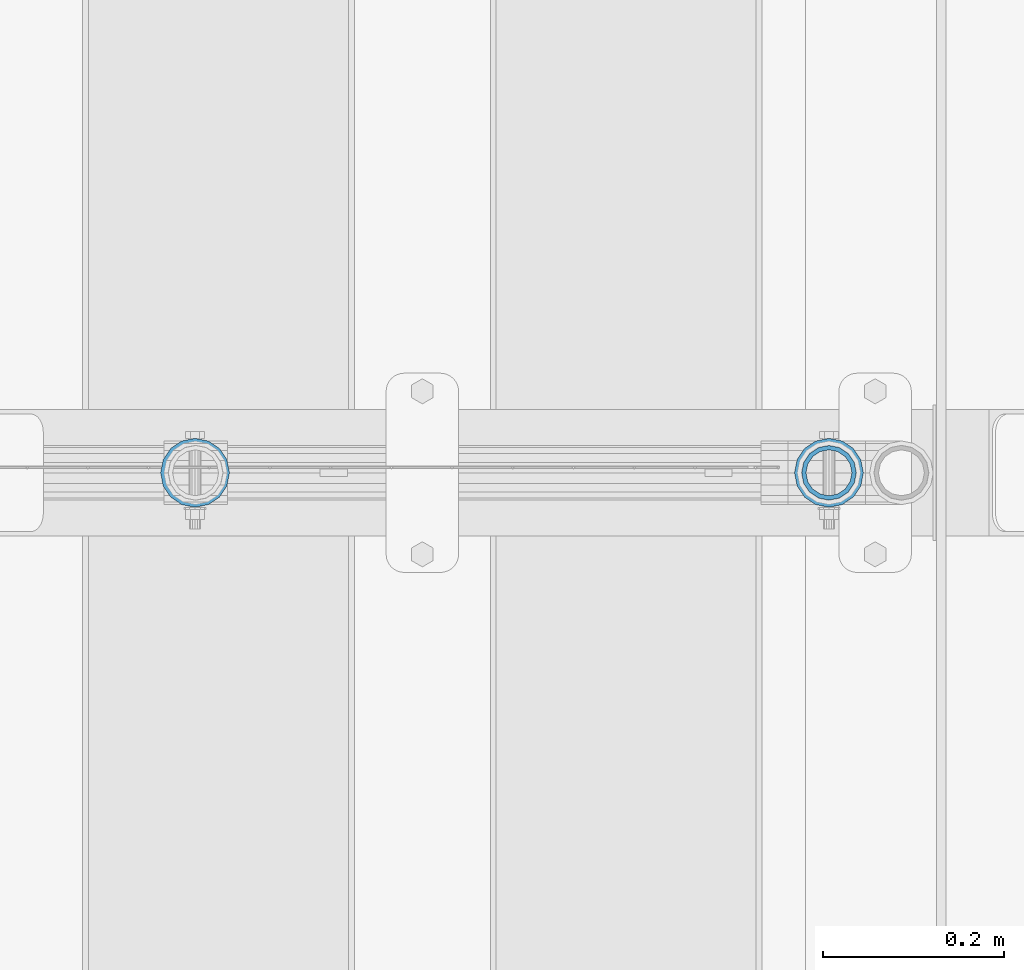
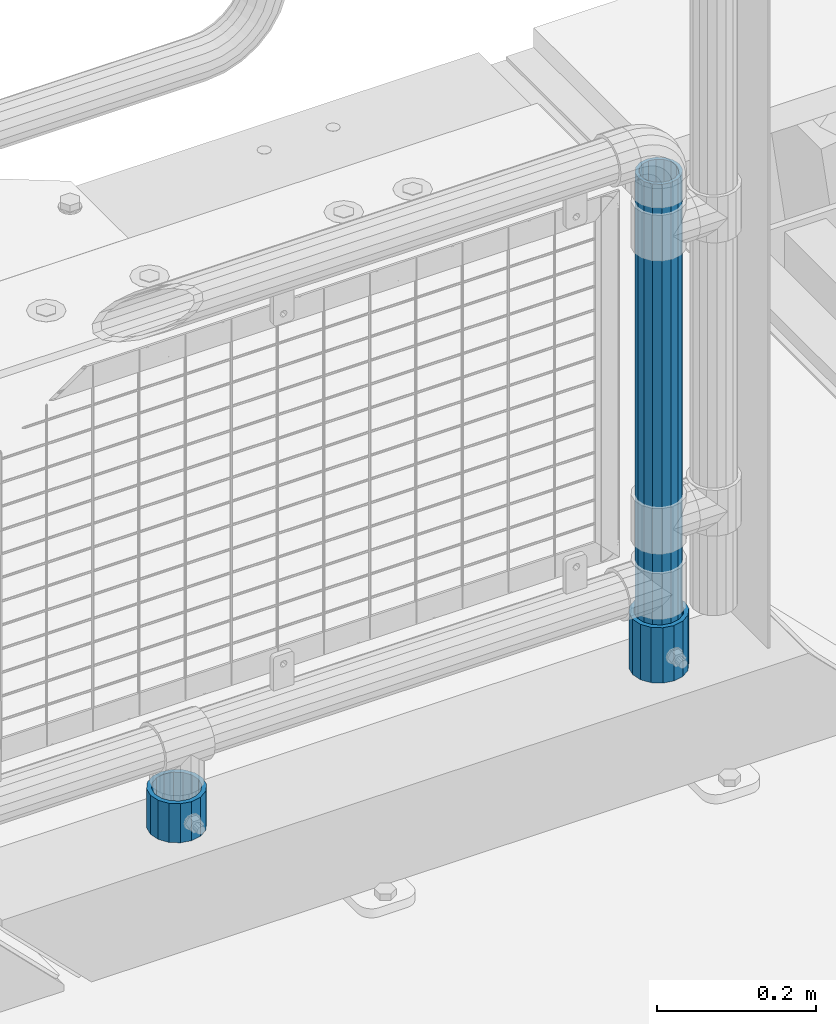
# One storey, part 108 of 242: 3 columns.
"""IFC2X3 building model written with IfcOpenShell, lengths in millimetres."""

import ifcopenshell
import ifcopenshell.guid

model = None  # the IFC model being written
_history = None  # IfcOwnerHistory: only IFC2X3 demands one
_inside = {}  # id of a spatial element -> (the spatial element, [elements in it])
_under = {}  # id of a project, library or spatial element -> (it, [spatial elements below it])
_declared = {}  # id of a project -> (the project, [libraries it declares])
_typed = {}  # id of a type object -> (the type object, [elements of that type])
_made_of = {}  # id of a material, layer set ... -> (it, [elements and type objects made of it])


def new_model(schema):
    """Start an empty IFC model of exactly this schema.

    Asked for "IFC4X3", IfcOpenShell would pick the latest addendum, in which some entities
    have other attributes; the version numbers below select the first issue.
    IFC2X3 requires an IfcOwnerHistory on every rooted entity: one is made here for all.
    """
    global model, _history
    if schema == "IFC4X3":
        model = ifcopenshell.file(schema_version=(4, 3, 0, 0))
    else:
        model = ifcopenshell.file(schema=schema)
    _inside.clear()
    _under.clear()
    _declared.clear()
    _typed.clear()
    _made_of.clear()
    _history = None
    if model.schema == "IFC2X3":
        org = make("IfcOrganization", Name="unknown")
        user = make(
            "IfcPersonAndOrganization",
            ThePerson=make("IfcPerson", FamilyName="unknown"),
            TheOrganization=org,
        )
        app = make(
            "IfcApplication",
            ApplicationDeveloper=org,
            Version="unknown",
            ApplicationFullName="unknown",
            ApplicationIdentifier="unknown",
        )
        _history = make(
            "IfcOwnerHistory",
            OwningUser=user,
            OwningApplication=app,
            ChangeAction="ADDED",
            CreationDate=0,
        )
    return model


def make(cls, **values):
    """One entity of the class cls with the attributes given. An attribute that is None is left unset."""
    return model.create_entity(
        cls, **{name: value for name, value in values.items() if value is not None}
    )


def rooted(cls, **values):
    """An entity with a GlobalId (a new one), such as an element, a storey or a relation."""
    return make(cls, GlobalId=ifcopenshell.guid.new(), OwnerHistory=_history, **values)


def si_unit(unit_type, name, prefix=None):
    """IfcSIUnit, for example si_unit("LENGTHUNIT", "METRE", prefix="MILLI")."""
    return make("IfcSIUnit", UnitType=unit_type, Prefix=prefix, Name=name)


def assignment(units):
    """IfcUnitAssignment: the units of a project."""
    return None if units is None else make("IfcUnitAssignment", Units=units)


def point(xyz):
    """IfcCartesianPoint."""
    return None if xyz is None else make("IfcCartesianPoint", Coordinates=xyz)


def direction(xyz):
    """IfcDirection."""
    return None if xyz is None else make("IfcDirection", DirectionRatios=xyz)


def frame(location, z_axis=None, x_axis=None):
    """IfcAxis2Placement3D, a coordinate frame: its origin and axes. An axis left out is left unset."""
    return make(
        "IfcAxis2Placement3D",
        Location=point(location),
        Axis=direction(z_axis),
        RefDirection=direction(x_axis),
    )


def origin_with_axes():
    """The frame at (0, 0, 0) with the z axis (0, 0, 1) and the x axis (1, 0, 0) written out."""
    return frame((0.0, 0.0, 0.0), z_axis=(0.0, 0.0, 1.0), x_axis=(1.0, 0.0, 0.0))


def place(relative_to, where):
    """IfcLocalPlacement: puts the frame where relative to a parent placement (None: the world)."""
    return make(
        "IfcLocalPlacement", PlacementRelTo=relative_to, RelativePlacement=where
    )


def context(
    kind, dimensions, precision=None, world=None, true_north=None, identifier=None
):
    """IfcGeometricRepresentationContext, for example the 3D "Model" context."""
    return make(
        "IfcGeometricRepresentationContext",
        ContextIdentifier=identifier,
        ContextType=kind,
        CoordinateSpaceDimension=dimensions,
        Precision=precision,
        WorldCoordinateSystem=world,
        TrueNorth=true_north,
    )


def subcontext(parent, identifier, kind, view, scale=None):
    """IfcGeometricRepresentationSubContext, for example "Body" below "Model"."""
    return make(
        "IfcGeometricRepresentationSubContext",
        ContextIdentifier=identifier,
        ContextType=kind,
        ParentContext=parent,
        TargetScale=scale,
        TargetView=view,
    )


def project(units=None, contexts=None):
    """IfcProject with its units and contexts."""
    return rooted(
        "IfcProject",
        Name="project",
        RepresentationContexts=contexts,
        UnitsInContext=assignment(units),
    )


def spatial(cls, under=None, at=None, **own):
    """A site, building, storey or space (cls), placed at a placement, below another one or the project."""
    s = rooted(cls, ObjectPlacement=at, **own)
    if under is not None:
        _under.setdefault(under.id(), (under, []))[1].append(s)
    return s


def faces_of(points, faces, orient=None, outer=None):
    """IfcFace entities. A face is a list of loops; a loop is a list of indices into points, from 0.

    orient and outer hold one flag for each loop. By default every Orientation is true, the
    first loop of a face is its IfcFaceOuterBound and the others are IfcFaceBound.
    """
    made = []
    for i, loops in enumerate(faces):
        bounds = []
        for j, loop in enumerate(loops):
            is_outer = j == 0 if outer is None else outer[i][j]
            bounds.append(
                make(
                    "IfcFaceOuterBound" if is_outer else "IfcFaceBound",
                    Bound=make("IfcPolyLoop", Polygon=[points[k] for k in loop]),
                    Orientation=True if orient is None else orient[i][j],
                )
            )
        made.append(make("IfcFace", Bounds=bounds))
    return made


def faceted_brep(points, faces, orient=None, outer=None, voids=None):
    """IfcFacetedBrep: a solid bounded by flat faces; with voids (closed shells), ...WithVoids."""
    shared = [point(p) for p in points]
    hull = make("IfcClosedShell", CfsFaces=faces_of(shared, faces, orient, outer))
    if voids is None:
        return make("IfcFacetedBrep", Outer=hull)
    return make(
        "IfcFacetedBrepWithVoids",
        Outer=hull,
        Voids=[
            make(cls, CfsFaces=faces_of(shared, fs, o, b)) for cls, fs, o, b in voids
        ],
    )


def shape(context_of_items, identifier, shape_type, items):
    """IfcShapeRepresentation: the items that make up one representation, for example the "Body"."""
    return make(
        "IfcShapeRepresentation",
        ContextOfItems=context_of_items,
        RepresentationIdentifier=identifier,
        RepresentationType=shape_type,
        Items=items,
    )


def material(Name=None, Category=None):
    """IfcMaterial."""
    return make("IfcMaterial", Name=Name, Category=Category)


def made_of(thing, what):
    """Note that an element or type object is made of a material, layer set ...; save() writes the relation."""
    if what is not None:
        _made_of.setdefault(what.id(), (what, []))[1].append(thing)
    return thing


def type_object(cls, material=None, **own):
    """A type object (cls), such as IfcWallType, which elements share."""
    return made_of(rooted(cls, **own), material)


def element(
    cls,
    number,
    at=None,
    inside=None,
    cuts=None,
    type_object=None,
    material=None,
    context=None,
    identifier="Body",
    shape_type=None,
    held_by="IfcProductDefinitionShape",
    body=None,
    shapes=None,
    **own,
):
    """One element of the class cls, such as IfcWall. Its Tag is "e" and its number.

    at: its placement. inside: the storey or other place that contains it. cuts: it is an
    opening in that element (IfcRelVoidsElement). A single representation is given by context,
    identifier, shape_type and body (its items); several are given by shapes. held_by: the class
    of the entity that holds the representations. save() writes the other relations.
    """
    e = rooted(cls, Tag="e%d" % number, ObjectPlacement=at, **own)
    if body is not None:
        shapes = [shape(context, identifier, shape_type, body)]
    if shapes is not None:
        e.Representation = make(held_by, Representations=shapes)
    if inside is not None:
        _inside.setdefault(inside.id(), (inside, []))[1].append(e)
    if cuts is not None:
        rooted(
            "IfcRelVoidsElement", RelatingBuildingElement=cuts, RelatedOpeningElement=e
        )
    if type_object is not None:
        _typed.setdefault(type_object.id(), (type_object, []))[1].append(e)
    return made_of(e, material)


def aggregate(whole, parts):
    """IfcRelAggregates: a whole, such as a stair, and the parts it consists of."""
    return rooted("IfcRelAggregates", RelatingObject=whole, RelatedObjects=parts)


def save(model, path):
    """Write the relations noted so far, then the file.

    IfcRelAggregates (storeys below a building ...), IfcRelContainedInSpatialStructure (elements
    in a storey), IfcRelDefinesByType, IfcRelAssociatesMaterial and IfcRelDeclares: one each for
    every whole, place, type object, material and project.
    """
    for whole, parts in _under.values():
        aggregate(whole, parts)
    for where, things in _inside.values():
        rooted(
            "IfcRelContainedInSpatialStructure",
            RelatedElements=things,
            RelatingStructure=where,
        )
    for kind, things in _typed.values():
        rooted("IfcRelDefinesByType", RelatedObjects=things, RelatingType=kind)
    for what, things in _made_of.values():
        rooted("IfcRelAssociatesMaterial", RelatedObjects=things, RelatingMaterial=what)
    for by, libraries in _declared.values():
        rooted("IfcRelDeclares", RelatingContext=by, RelatedDefinitions=libraries)
    model.write(path)


model = new_model("IFC2X3")

# Units and contexts
model_context = context("Model", 3, precision=1e-05, world=origin_with_axes())
body_context = subcontext(model_context, "Body", "Model", "MODEL_VIEW")
ifc_project = project(units=[si_unit("LENGTHUNIT", "METRE", prefix="MILLI"), si_unit("AREAUNIT", "SQUARE_METRE"), si_unit("VOLUMEUNIT", "CUBIC_METRE"), si_unit("MASSUNIT", "GRAM", prefix="KILO"), si_unit("TIMEUNIT", "SECOND"), si_unit("PLANEANGLEUNIT", "RADIAN"), si_unit("SOLIDANGLEUNIT", "STERADIAN"), si_unit("THERMODYNAMICTEMPERATUREUNIT", "DEGREE_CELSIUS"), si_unit("LUMINOUSINTENSITYUNIT", "LUMEN")], contexts=[model_context])

# Site, building, storey
site_placement = place(None, origin_with_axes())
site = spatial("IfcSite", under=ifc_project, at=site_placement, CompositionType="ELEMENT")
building_placement = place(site_placement, origin_with_axes())
building = spatial("IfcBuilding", under=site, at=building_placement, Name="Standard", CompositionType="ELEMENT")
storey_placement = place(building_placement, origin_with_axes())
storey = spatial("IfcBuildingStorey", under=building, at=storey_placement, Name="Undefined", CompositionType="ELEMENT", Elevation=0.0)

# Columns
ifc_material = material()
column_type_1 = type_object("IfcColumnType", PredefinedType="NOTDEFINED")
column_1_placement = place(storey_placement, frame((-22656.0, -19335.5, 168.02), z_axis=(-1.0, 0.0, 0.0), x_axis=(0.0, 0.0, 1.0)))
element("IfcColumn", 1, at=column_1_placement, inside=storey, type_object=column_type_1, material=ifc_material, context=body_context, shape_type="Brep", body=[
    faceted_brep([(0.0, -25.3499999999985, 0.0), (0.0, -23.4203461491597, 9.70102501045403), (760.0, -23.4203461491597, 9.70102501045403), (760.0, -25.3499999999985, 0.0), (0.0, -17.9251569030785, 17.9251569030785), (760.0, -17.9251569030785, 17.9251569030785), (0.0, -9.70102501045403, 23.4203461491597), (760.0, -9.70102501045403, 23.4203461491597), (0.0, 0.0, 25.3499999999985), (760.0, 0.0, 25.3499999999985), (0.0, 9.70102501045403, 23.4203461491597), (760.0, 9.70102501045403, 23.4203461491597), (0.0, 17.9251569030785, 17.9251569030785), (760.0, 17.9251569030785, 17.9251569030785), (0.0, 23.4203461491597, 9.70102501045403), (760.0, 23.4203461491597, 9.70102501045403), (0.0, 25.3499999999985, 0.0), (760.0, 25.3499999999985, 0.0), (0.0, 23.4203461491597, -9.70102501045403), (760.0, 23.4203461491597, -9.70102501045403), (0.0, 17.9251569030785, -17.9251569030785), (760.0, 17.9251569030785, -17.9251569030785), (0.0, 9.70102501045403, -23.4203461491597), (760.0, 9.70102501045403, -23.4203461491597), (0.0, 0.0, -25.3499999999985), (760.0, 0.0, -25.3499999999985), (0.0, -9.70102501045403, -23.4203461491597), (760.0, -9.70102501045403, -23.4203461491597), (0.0, -17.9251569030785, -17.9251569030785), (760.0, -17.9251569030785, -17.9251569030785), (0.0, -23.4203461491597, -9.70102501045403), (760.0, -23.4203461491597, -9.70102501045403), (0.0, -30.1500000000015, 0.0), (0.0, -27.8549679052157, -11.5379054858058), (760.0, -27.8549679052157, -11.5379054858058), (760.0, -30.1500000000015, 0.0), (0.0, -21.3192694527752, -21.3192694527752), (760.0, -21.3192694527752, -21.3192694527752), (0.0, -11.5379054858058, -27.8549679052157), (760.0, -11.5379054858058, -27.8549679052157), (0.0, 0.0, -30.1500000000015), (760.0, 0.0, -30.1500000000015), (0.0, 11.5379054858058, -27.8549679052157), (760.0, 11.5379054858058, -27.8549679052157), (0.0, 21.3192694527752, -21.3192694527752), (760.0, 21.3192694527752, -21.3192694527752), (0.0, 27.8549679052157, -11.5379054858058), (760.0, 27.8549679052157, -11.5379054858058), (0.0, 30.1500000000015, 0.0), (760.0, 30.1500000000015, 0.0), (0.0, 27.8549679052157, 11.5379054858058), (760.0, 27.8549679052157, 11.5379054858058), (0.0, 21.3192694527752, 21.3192694527752), (760.0, 21.3192694527752, 21.3192694527752), (0.0, 11.5379054858058, 27.8549679052157), (760.0, 11.5379054858058, 27.8549679052157), (0.0, 0.0, 30.1500000000015), (760.0, 0.0, 30.1500000000015), (0.0, -11.5379054858058, 27.8549679052157), (760.0, -11.5379054858058, 27.8549679052157), (0.0, -21.3192694527752, 21.3192694527752), (760.0, -21.3192694527752, 21.3192694527752), (0.0, -27.8549679052157, 11.5379054858058), (760.0, -27.8549679052157, 11.5379054858058)], [[[0, 1, 2, 3]], [[1, 4, 5, 2]], [[4, 6, 7, 5]], [[6, 8, 9, 7]], [[8, 10, 11, 9]], [[10, 12, 13, 11]], [[12, 14, 15, 13]], [[14, 16, 17, 15]], [[16, 18, 19, 17]], [[18, 20, 21, 19]], [[20, 22, 23, 21]], [[22, 24, 25, 23]], [[24, 26, 27, 25]], [[26, 28, 29, 27]], [[28, 30, 31, 29]], [[30, 0, 3, 31]], [[32, 33, 34, 35]], [[33, 36, 37, 34]], [[36, 38, 39, 37]], [[38, 40, 41, 39]], [[40, 42, 43, 41]], [[42, 44, 45, 43]], [[44, 46, 47, 45]], [[46, 48, 49, 47]], [[48, 50, 51, 49]], [[50, 52, 53, 51]], [[52, 54, 55, 53]], [[54, 56, 57, 55]], [[56, 58, 59, 57]], [[58, 60, 61, 59]], [[60, 62, 63, 61]], [[62, 32, 35, 63]], [[37, 39, 41, 43, 45, 47, 49, 51, 53, 55, 57, 59, 61, 63, 35, 34], [5, 7, 9, 11, 13, 15, 17, 19, 21, 23, 25, 27, 29, 31, 3, 2]], [[62, 60, 58, 56, 54, 52, 50, 48, 46, 44, 42, 40, 38, 36, 33, 32], [30, 28, 26, 24, 22, 20, 18, 16, 14, 12, 10, 8, 6, 4, 1, 0]]]),
])
column_type_2 = type_object("IfcColumnType", PredefinedType="NOTDEFINED")
column_2_placement = place(storey_placement, frame((-23356.0, -19335.5, 168.019999999998), z_axis=(0.0, 1.0, 0.0), x_axis=(0.0, 0.0, 1.0)))
element("IfcColumn", 2, at=column_2_placement, inside=storey, type_object=column_type_2, material=ifc_material, context=body_context, shape_type="Brep", body=[
    faceted_brep([(0.0, -31.75, 0.0), (0.0, -29.3331751572332, 12.1501989775934), (60.0, -29.3331751572332, 12.1501989775934), (60.0, -31.75, 0.0), (0.0, -22.4506403026717, 22.4506403026717), (60.0, -22.4506403026717, 22.4506403026717), (0.0, -12.1501989775934, 29.3331751572332), (60.0, -12.1501989775934, 29.3331751572332), (0.0, 0.0, 31.75), (60.0, 0.0, 31.75), (0.0, 12.1501989775934, 29.3331751572332), (60.0, 12.1501989775934, 29.3331751572332), (0.0, 22.4506403026717, 22.4506403026717), (60.0, 22.4506403026717, 22.4506403026717), (0.0, 29.3331751572332, 12.1501989775934), (60.0, 29.3331751572332, 12.1501989775934), (0.0, 31.75, 0.0), (60.0, 31.75, 0.0), (0.0, 29.3331751572332, -12.1501989775934), (60.0, 29.3331751572332, -12.1501989775934), (0.0, 22.4506403026717, -22.4506403026717), (60.0, 22.4506403026717, -22.4506403026717), (0.0, 12.1501989775934, -29.3331751572332), (60.0, 12.1501989775934, -29.3331751572332), (0.0, 0.0, -31.75), (60.0, 0.0, -31.75), (0.0, -12.1501989775934, -29.3331751572332), (60.0, -12.1501989775934, -29.3331751572332), (0.0, -22.4506403026717, -22.4506403026717), (60.0, -22.4506403026717, -22.4506403026717), (0.0, -29.3331751572332, -12.1501989775934), (60.0, -29.3331751572332, -12.1501989775934), (0.0, -38.0499999999993, 0.0), (0.0, -35.1536162120537, -14.5611046014928), (60.0, -35.1536162120537, -14.5611046014928), (60.0, -38.0499999999993, 0.0), (0.0, -26.9054130241493, -26.9054130241493), (60.0, -26.9054130241493, -26.9054130241493), (0.0, -14.5611046014928, -35.1536162120537), (60.0, -14.5611046014928, -35.1536162120537), (0.0, 0.0, -38.0499999999993), (60.0, 0.0, -38.0499999999993), (0.0, 14.5611046014928, -35.1536162120537), (60.0, 14.5611046014928, -35.1536162120537), (0.0, 26.9054130241493, -26.9054130241493), (60.0, 26.9054130241493, -26.9054130241493), (0.0, 35.1536162120537, -14.5611046014928), (60.0, 35.1536162120537, -14.5611046014928), (0.0, 38.0499999999993, 0.0), (60.0, 38.0499999999993, 0.0), (0.0, 35.1536162120537, 14.5611046014928), (60.0, 35.1536162120537, 14.5611046014928), (0.0, 26.9054130241493, 26.9054130241493), (60.0, 26.9054130241493, 26.9054130241493), (0.0, 14.5611046014928, 35.1536162120537), (60.0, 14.5611046014928, 35.1536162120537), (0.0, 0.0, 38.0499999999993), (60.0, 0.0, 38.0499999999993), (0.0, -14.5611046014928, 35.1536162120537), (60.0, -14.5611046014928, 35.1536162120537), (0.0, -26.9054130241493, 26.9054130241493), (60.0, -26.9054130241493, 26.9054130241493), (0.0, -35.1536162120537, 14.5611046014928), (60.0, -35.1536162120537, 14.5611046014928)], [[[0, 1, 2, 3]], [[1, 4, 5, 2]], [[4, 6, 7, 5]], [[6, 8, 9, 7]], [[8, 10, 11, 9]], [[10, 12, 13, 11]], [[12, 14, 15, 13]], [[14, 16, 17, 15]], [[16, 18, 19, 17]], [[18, 20, 21, 19]], [[20, 22, 23, 21]], [[22, 24, 25, 23]], [[24, 26, 27, 25]], [[26, 28, 29, 27]], [[28, 30, 31, 29]], [[30, 0, 3, 31]], [[32, 33, 34, 35]], [[33, 36, 37, 34]], [[36, 38, 39, 37]], [[38, 40, 41, 39]], [[40, 42, 43, 41]], [[42, 44, 45, 43]], [[44, 46, 47, 45]], [[46, 48, 49, 47]], [[48, 50, 51, 49]], [[50, 52, 53, 51]], [[52, 54, 55, 53]], [[54, 56, 57, 55]], [[56, 58, 59, 57]], [[58, 60, 61, 59]], [[60, 62, 63, 61]], [[62, 32, 35, 63]], [[37, 39, 41, 43, 45, 47, 49, 51, 53, 55, 57, 59, 61, 63, 35, 34], [5, 7, 9, 11, 13, 15, 17, 19, 21, 23, 25, 27, 29, 31, 3, 2]], [[62, 60, 58, 56, 54, 52, 50, 48, 46, 44, 42, 40, 38, 36, 33, 32], [30, 28, 26, 24, 22, 20, 18, 16, 14, 12, 10, 8, 6, 4, 1, 0]]]),
])
column_3_placement = place(storey_placement, frame((-22656.0, -19335.5, 168.02), z_axis=(0.0, 1.0, 0.0), x_axis=(0.0, 0.0, 1.0)))
element("IfcColumn", 3, at=column_3_placement, inside=storey, type_object=column_type_2, material=ifc_material, context=body_context, shape_type="Brep", body=[
    faceted_brep([(0.0, -31.75, 0.0), (0.0, -29.3331751572332, 12.1501989775934), (85.0, -29.3331751572332, 12.1501989775934), (85.0, -31.75, 0.0), (0.0, -22.4506403026717, 22.4506403026717), (85.0, -22.4506403026717, 22.4506403026717), (0.0, -12.1501989775934, 29.3331751572332), (85.0, -12.1501989775934, 29.3331751572332), (0.0, 0.0, 31.75), (85.0, 0.0, 31.75), (0.0, 12.1501989775934, 29.3331751572332), (85.0, 12.1501989775934, 29.3331751572332), (0.0, 22.4506403026717, 22.4506403026717), (85.0, 22.4506403026717, 22.4506403026717), (0.0, 29.3331751572332, 12.1501989775934), (85.0, 29.3331751572332, 12.1501989775934), (0.0, 31.75, 0.0), (85.0, 31.75, 0.0), (0.0, 29.3331751572332, -12.1501989775934), (85.0, 29.3331751572332, -12.1501989775934), (0.0, 22.4506403026717, -22.4506403026717), (85.0, 22.4506403026717, -22.4506403026717), (0.0, 12.1501989775934, -29.3331751572332), (85.0, 12.1501989775934, -29.3331751572332), (0.0, 0.0, -31.75), (85.0, 0.0, -31.75), (0.0, -12.1501989775934, -29.3331751572332), (85.0, -12.1501989775934, -29.3331751572332), (0.0, -22.4506403026717, -22.4506403026717), (85.0, -22.4506403026717, -22.4506403026717), (0.0, -29.3331751572332, -12.1501989775934), (85.0, -29.3331751572332, -12.1501989775934), (0.0, -38.0499999999993, 0.0), (0.0, -35.1536162120537, -14.5611046014928), (85.0, -35.1536162120537, -14.5611046014928), (85.0, -38.0499999999993, 0.0), (0.0, -26.9054130241493, -26.9054130241493), (85.0, -26.9054130241493, -26.9054130241493), (0.0, -14.5611046014928, -35.1536162120537), (85.0, -14.5611046014928, -35.1536162120537), (0.0, 0.0, -38.0499999999993), (85.0, 0.0, -38.0499999999993), (0.0, 14.5611046014928, -35.1536162120537), (85.0, 14.5611046014928, -35.1536162120537), (0.0, 26.9054130241493, -26.9054130241493), (85.0, 26.9054130241493, -26.9054130241493), (0.0, 35.1536162120537, -14.5611046014928), (85.0, 35.1536162120537, -14.5611046014928), (0.0, 38.0499999999993, 0.0), (85.0, 38.0499999999993, 0.0), (0.0, 35.1536162120537, 14.5611046014928), (85.0, 35.1536162120537, 14.5611046014928), (0.0, 26.9054130241493, 26.9054130241493), (85.0, 26.9054130241493, 26.9054130241493), (0.0, 14.5611046014928, 35.1536162120537), (85.0, 14.5611046014928, 35.1536162120537), (0.0, 0.0, 38.0499999999993), (85.0, 0.0, 38.0499999999993), (0.0, -14.5611046014928, 35.1536162120537), (85.0, -14.5611046014928, 35.1536162120537), (0.0, -26.9054130241493, 26.9054130241493), (85.0, -26.9054130241493, 26.9054130241493), (0.0, -35.1536162120537, 14.5611046014928), (85.0, -35.1536162120537, 14.5611046014928)], [[[0, 1, 2, 3]], [[1, 4, 5, 2]], [[4, 6, 7, 5]], [[6, 8, 9, 7]], [[8, 10, 11, 9]], [[10, 12, 13, 11]], [[12, 14, 15, 13]], [[14, 16, 17, 15]], [[16, 18, 19, 17]], [[18, 20, 21, 19]], [[20, 22, 23, 21]], [[22, 24, 25, 23]], [[24, 26, 27, 25]], [[26, 28, 29, 27]], [[28, 30, 31, 29]], [[30, 0, 3, 31]], [[32, 33, 34, 35]], [[33, 36, 37, 34]], [[36, 38, 39, 37]], [[38, 40, 41, 39]], [[40, 42, 43, 41]], [[42, 44, 45, 43]], [[44, 46, 47, 45]], [[46, 48, 49, 47]], [[48, 50, 51, 49]], [[50, 52, 53, 51]], [[52, 54, 55, 53]], [[54, 56, 57, 55]], [[56, 58, 59, 57]], [[58, 60, 61, 59]], [[60, 62, 63, 61]], [[62, 32, 35, 63]], [[37, 39, 41, 43, 45, 47, 49, 51, 53, 55, 57, 59, 61, 63, 35, 34], [5, 7, 9, 11, 13, 15, 17, 19, 21, 23, 25, 27, 29, 31, 3, 2]], [[62, 60, 58, 56, 54, 52, 50, 48, 46, 44, 42, 40, 38, 36, 33, 32], [30, 28, 26, 24, 22, 20, 18, 16, 14, 12, 10, 8, 6, 4, 1, 0]]]),
])

save(model, "model.ifc")
